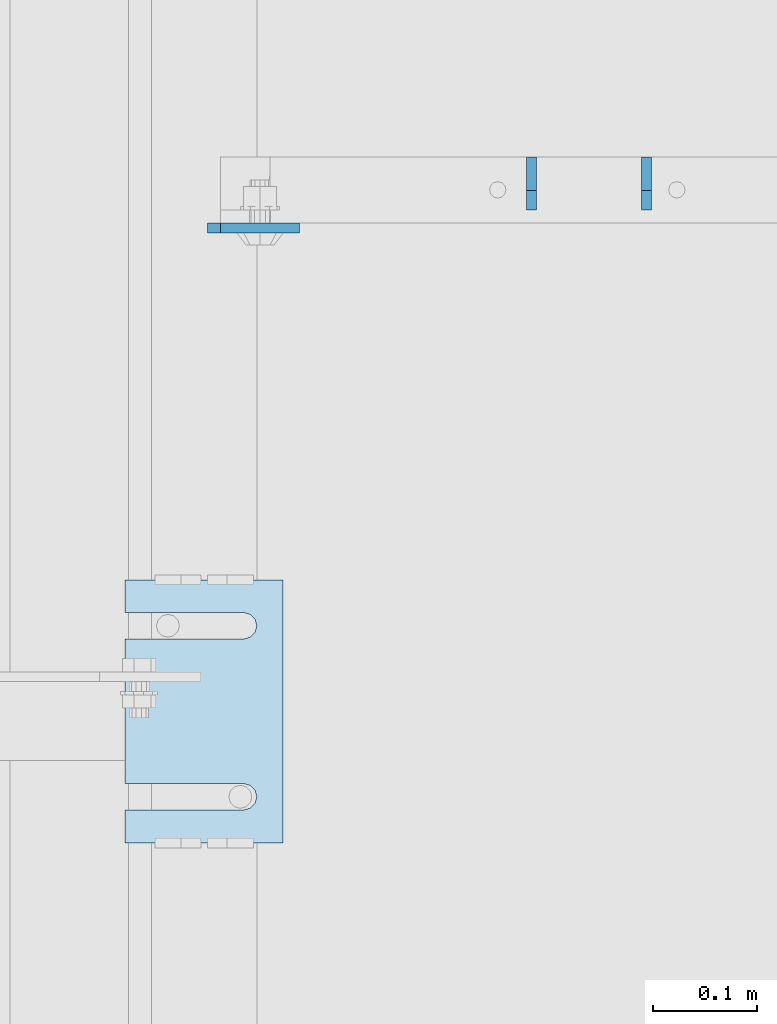
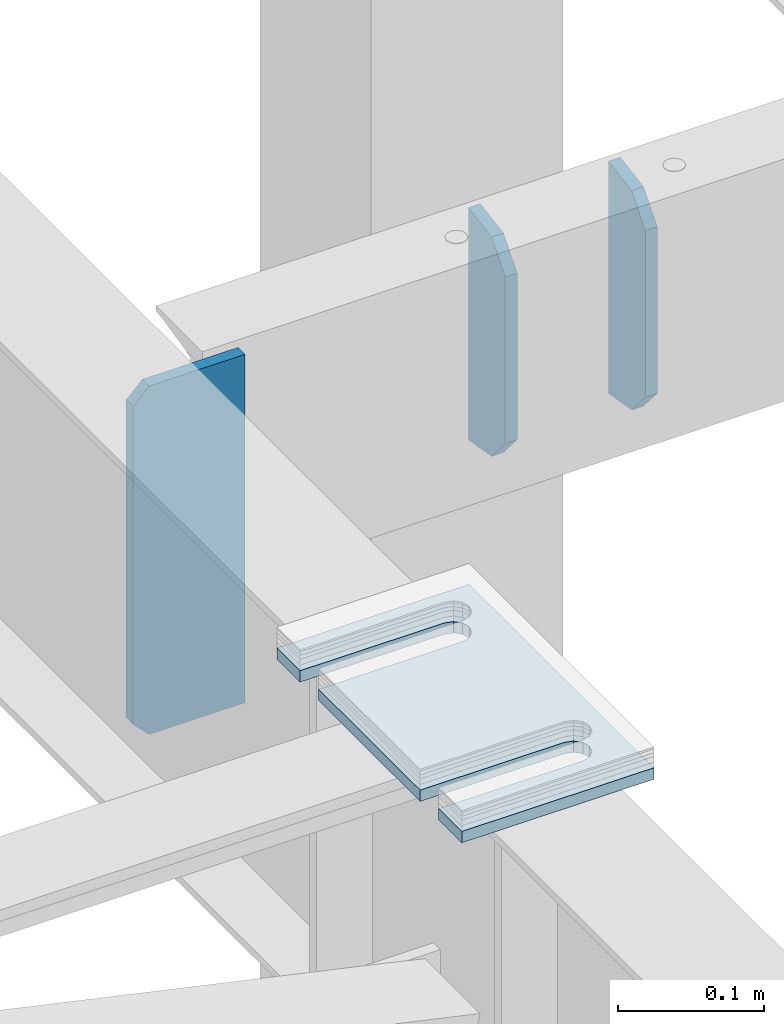
# One storey, part 1788 of 1876: 4 plates, 3 elements without a shape of their own.
"""IFC2X3 building model written with IfcOpenShell, lengths in millimetres."""

from ifc_helpers import new_model, si_unit, frame, origin_with_axes, place, context, subcontext, project, spatial, faceted_brep, material, type_object, element, aggregate, save


model = new_model("IFC2X3")

# Units and contexts
model_context = context("Model", 3, precision=1e-05, world=origin_with_axes())
body_context = subcontext(model_context, "Body", "Model", "MODEL_VIEW")
ifc_project = project(units=[si_unit("LENGTHUNIT", "METRE", prefix="MILLI"), si_unit("AREAUNIT", "SQUARE_METRE"), si_unit("VOLUMEUNIT", "CUBIC_METRE"), si_unit("MASSUNIT", "GRAM", prefix="KILO"), si_unit("TIMEUNIT", "SECOND"), si_unit("PLANEANGLEUNIT", "RADIAN"), si_unit("SOLIDANGLEUNIT", "STERADIAN"), si_unit("THERMODYNAMICTEMPERATUREUNIT", "DEGREE_CELSIUS"), si_unit("LUMINOUSINTENSITYUNIT", "LUMEN")], contexts=[model_context])

# Site, building, storey
site_placement = place(None, origin_with_axes())
site = spatial("IfcSite", under=ifc_project, at=site_placement, CompositionType="ELEMENT")
building_placement = place(site_placement, origin_with_axes())
building = spatial("IfcBuilding", under=site, at=building_placement, Name="Undefined", CompositionType="ELEMENT")
storey_placement = place(building_placement, origin_with_axes())
storey = spatial("IfcBuildingStorey", under=building, at=storey_placement, Name="Undefined", CompositionType="ELEMENT", Elevation=0.0)

# Assembly, plate
assembly_1_placement = place(storey_placement, origin_with_axes())
assembly_1 = element("IfcElementAssembly", 1, at=assembly_1_placement, inside=storey, Name="BEAM", AssemblyPlace="NOTDEFINED", PredefinedType="RIGID_FRAME")
ifc_material = material(Name="STEEL/A36")
plate_type_1 = type_object("IfcPlateType", PredefinedType="NOTDEFINED")
plate_1_placement = place(assembly_1_placement, frame((3835.4, 11947.5245000839, 17684.75), z_axis=(0.0, 0.0, 1.0), x_axis=(1.0, 0.0, 0.0)))
plate_1 = element("IfcPlate", 2, at=plate_1_placement, type_object=plate_type_1, material=ifc_material, Name="PLATE", context=body_context, shape_type="Brep", body=[
    faceted_brep([(3.7040990719106e-08, -4.76249999999982, 12.6999998092651), (0.0, -4.76249999999982, 279.40000629425), (0.0, 4.76249999999982, 279.40000629425), (3.70396264770534e-08, 4.76249999999982, 12.6999998092651), (12.6999998092651, -4.76249999999982, 292.100006103516), (12.6999998092651, 4.76249999999982, 292.100006103516), (88.9000015258789, -4.76249999999982, 292.100006103516), (88.9000015258789, 4.76249999999982, 292.100006103516), (88.9000015258789, -4.76249999999982, 0.0), (88.9000015258789, 4.76249999999982, 0.0), (12.699999809267, -4.76249999999754, 1.09139364212751e-11), (12.6999998092651, 4.76250000000255, 1.09139364212751e-11)], [[[0, 1, 2, 3]], [[1, 4, 5, 2]], [[4, 6, 7, 5]], [[6, 8, 9, 7]], [[8, 10, 11, 9]], [[10, 0, 3, 11]], [[5, 7, 9, 11, 3, 2]], [[10, 8, 6, 4, 1, 0]]]),
])
aggregate(assembly_1, [plate_1])

assembly_2_placement = place(storey_placement, origin_with_axes())
assembly_2 = element("IfcElementAssembly", 3, at=assembly_2_placement, inside=storey, Name="SHIM PLATE", AssemblyPlace="NOTDEFINED", PredefinedType="RIGID_FRAME")
plate_type_2 = type_object("IfcPlateType", PredefinedType="NOTDEFINED")
plate_2_placement = place(assembly_2_placement, frame((3908.44515556446, 11353.8028259277, 17987.9625), z_axis=(-1.0, 0.0, 0.0), x_axis=(0.0, 1.0, 0.0)))
plate_2 = element("IfcPlate", 4, at=plate_2_placement, type_object=plate_type_2, material=ifc_material, Name="SHIM PLATE", context=body_context, shape_type="Brep", body=[
    faceted_brep([(31.7473236467022, -4.76250000000073, 152.398895263674), (31.7495452849444, -4.76250000000073, 38.0994505459066), (31.7495452849444, 4.76250000000073, 38.0994505459066), (31.7473236467022, 4.76250000000073, 152.398895263674), (33.4510181364694, -4.76250000000073, 31.7494480392982), (33.4510181364694, 4.76250000000073, 31.7494480392982), (38.0995388011806, -4.76250000000073, 27.1009216783834), (38.0995388011806, 4.76250000000073, 27.1009216783834), (44.4495392228328, -4.76250000000073, 25.3994410457015), (44.4495392228328, 4.76250000000073, 25.3994410457015), (50.7995409628356, -4.76250000000073, 27.1009167582527), (50.7995409628356, 4.76250000000073, 27.1009167582527), (55.4480652293469, -4.76250000000073, 31.7494395173824), (55.4480652293469, 4.76250000000073, 31.7494395173824), (57.14954300102, -4.76250000000073, 38.0994407056476), (57.14954300102, 4.76250000000073, 38.0994407056476), (57.1473213626687, -4.76250000000073, 152.398894419415), (57.1473213626687, 4.76250000000073, 152.398895263676), (0.0, -4.76249999999982, 0.0), (1.98255729628727e-05, -4.76250000000073, 152.398895263672), (1.98255729628727e-05, 4.76250000000073, 152.398895263672), (0.0, 4.76249999999982, 0.0), (253.999542236328, -4.76250000000073, 6.16182660451159e-11), (253.999542236328, 4.76250000000073, 6.16182660451159e-11), (253.999557495107, -4.76250000000073, 152.398895263688), (253.999557495107, 4.76250000000073, 152.398895263688), (222.247321362667, 4.76250000000073, 152.398895263686), (222.247321362667, -4.76250000000073, 152.398895410166), (222.249543001019, 4.76250000000073, 38.0994416963979), (222.249543001019, -4.76250000000073, 38.0994416963979), (220.548065229345, 4.76250000000073, 31.7494405081325), (220.548065229345, -4.76250000000073, 31.7494405081325), (215.899540962834, 4.76250000000073, 27.100917749003), (215.899540962834, -4.76250000000073, 27.100917749003), (209.549539222831, 4.76250000000073, 25.3994420364518), (209.549539222831, -4.76250000000073, 25.3994420364518), (203.199538801179, 4.76250000000073, 27.1009226691335), (203.199538801179, -4.76250000000073, 27.1009226691335), (198.551018136468, 4.76250000000073, 31.7494490300483), (198.551018136468, -4.76250000000073, 31.7494490300483), (196.849545284943, 4.76250000000073, 38.0994515366567), (196.849545284943, -4.76250000000073, 38.0994515366567), (196.847323646701, -4.76250000000073, 152.398895263684), (196.847323646701, 4.76250000000073, 152.398895263684)], [[[0, 1, 2, 3]], [[4, 5, 2, 1]], [[6, 7, 5, 4]], [[8, 9, 7, 6]], [[10, 11, 9, 8]], [[12, 13, 11, 10]], [[14, 15, 13, 12]], [[16, 17, 15, 14]], [[18, 19, 20, 21]], [[22, 18, 21, 23]], [[24, 22, 23, 25]], [[24, 25, 26, 27]], [[27, 26, 28, 29]], [[29, 28, 30, 31]], [[31, 30, 32, 33]], [[33, 32, 34, 35]], [[35, 34, 36, 37]], [[37, 36, 38, 39]], [[39, 38, 40, 41]], [[42, 41, 40, 43]], [[12, 10, 8, 6, 4, 1, 0, 19, 18, 22, 24, 27, 29, 31, 33, 35, 37, 39, 41, 42, 16, 14]], [[20, 19, 0, 3]], [[43, 40, 38, 36, 34, 32, 30, 28, 26, 25, 23, 21, 20, 3, 2, 5, 7, 9, 11, 13, 15, 17]], [[42, 43, 17, 16]]]),
])
aggregate(assembly_2, [plate_2])

# Assembly, plates
assembly_3_placement = place(storey_placement, origin_with_axes())
assembly_3 = element("IfcElementAssembly", 5, at=assembly_3_placement, inside=storey, Name="BEAM", AssemblyPlace="NOTDEFINED", PredefinedType="RIGID_FRAME")
plate_type_3 = type_object("IfcPlateType", PredefinedType="NOTDEFINED")
plate_3_placement = place(assembly_3_placement, frame((4148.13743973152, 12015.7875, 17978.9641886913), z_axis=(0.0, 0.164348990067108, -0.986402255402897), x_axis=(0.0, -0.986402255402897, -0.164348990067107)))
plate_3 = element("IfcPlate", 6, at=plate_3_placement, type_object=plate_type_3, material=ifc_material, Name="PLATE", context=body_context, shape_type="Brep", body=[
    faceted_brep([(0.0, -4.76249999999982, 0.0), (32.0008087158794, -4.76249999999982, 192.081680297815), (32.0008087158794, 4.76249999999982, 192.081680297815), (0.0, 4.76249999999982, 0.0), (62.6982748962027, -4.76249999999982, 181.561281061485), (62.6982748962027, 4.76249999999982, 181.561281061485), (77.5887637589458, -4.76249999999982, 156.594231983478), (77.5887637589458, 4.76249999999982, 156.594231983478), (54.6307491805464, -4.76249999999982, 18.791006663906), (54.6307491805464, 4.76249999999982, 18.791006663906), (32.4501686096137, -4.76249999999982, -1.63709046319127e-11), (32.4501686096137, 4.76249999999982, -1.63709046319127e-11)], [[[0, 1, 2, 3]], [[1, 4, 5, 2]], [[4, 6, 7, 5]], [[6, 8, 9, 7]], [[8, 10, 11, 9]], [[10, 0, 3, 11]], [[5, 7, 9, 11, 3, 2]], [[10, 8, 6, 4, 1, 0]]]),
])
plate_4_placement = place(assembly_3_placement, frame((4259.26243973152, 12015.7875, 17978.9642762055), z_axis=(0.0, 0.164348990067108, -0.986402255402897), x_axis=(0.0, -0.986402255402897, -0.164348990067107)))
plate_4 = element("IfcPlate", 7, at=plate_4_placement, type_object=plate_type_3, material=ifc_material, Name="PLATE", context=body_context, shape_type="Brep", body=[
    faceted_brep([(0.0, -4.76249999999982, 0.0), (32.0008087158794, -4.76249999999982, 192.081680297815), (32.0008087158794, 4.76249999999982, 192.081680297815), (0.0, 4.76249999999982, 0.0), (62.6982748962027, -4.76249999999982, 181.561281061485), (62.6982748962027, 4.76249999999982, 181.561281061485), (77.5887637589458, -4.76249999999982, 156.594231983478), (77.5887637589458, 4.76249999999982, 156.594231983478), (54.6307491805464, -4.76249999999982, 18.791006663906), (54.6307491805464, 4.76249999999982, 18.791006663906), (32.4501686096137, -4.76249999999982, -1.63709046319127e-11), (32.4501686096137, 4.76249999999982, -1.63709046319127e-11)], [[[0, 1, 2, 3]], [[1, 4, 5, 2]], [[4, 6, 7, 5]], [[6, 8, 9, 7]], [[8, 10, 11, 9]], [[10, 0, 3, 11]], [[5, 7, 9, 11, 3, 2]], [[10, 8, 6, 4, 1, 0]]]),
])
aggregate(assembly_3, [plate_3, plate_4])

save(model, "model.ifc")
